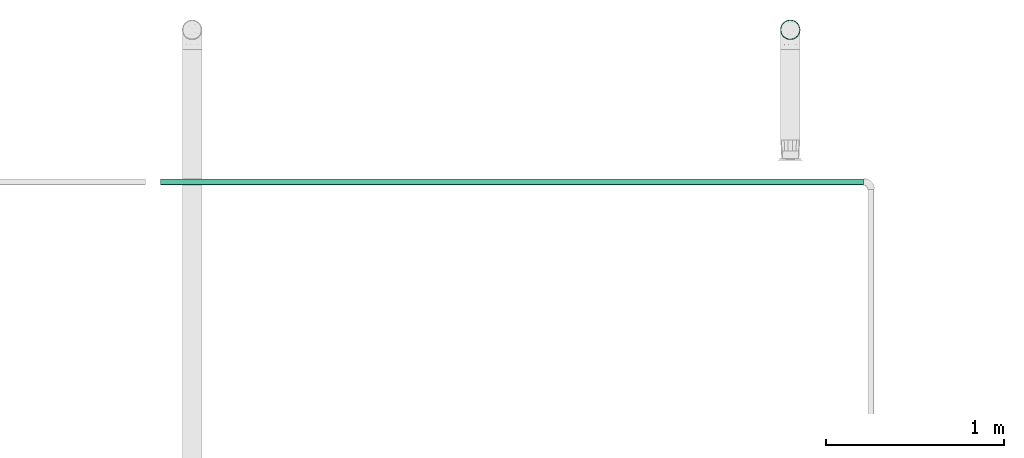
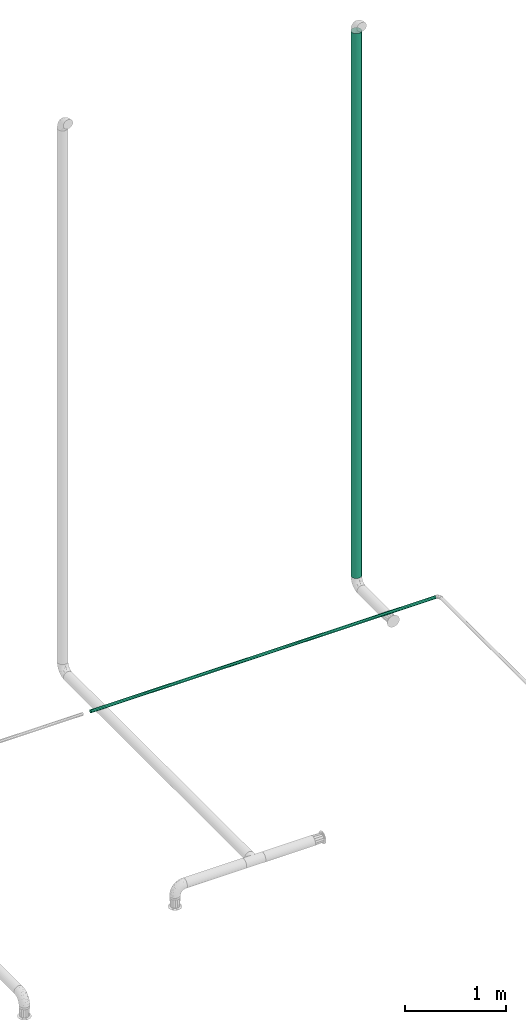
# One storey, part 22 of 123: 2 flow segments.
"""IFC2X3 building model written with IfcOpenShell, lengths in millimetres."""

from ifc_helpers import new_model, entity, si_unit, converted_unit, derived_unit, direction, frame, origin_with_axes, origin_2d_with_axis, place, context, subcontext, project, spatial, hollow_circle, extrude, source, transform, mapped, material, layer, layer_set, layer_usage, type_object, element, save


model = new_model("IFC2X3")

# Units and contexts
model_context = context("Model", 3, precision=1e-05, world=origin_with_axes(), true_north=direction((0.0, 1.0)))
body_context = subcontext(model_context, "Body", "Model", "MODEL_VIEW")
ifc_project = project(units=[si_unit("AREAUNIT", "SQUARE_METRE"), si_unit("VOLUMEUNIT", "CUBIC_METRE", prefix="DECI"), si_unit("TIMEUNIT", "SECOND"), si_unit("THERMODYNAMICTEMPERATUREUNIT", "DEGREE_CELSIUS"), si_unit("PRESSUREUNIT", "PASCAL"), si_unit("MASSUNIT", "GRAM", prefix="KILO"), si_unit("LENGTHUNIT", "METRE", prefix="MILLI"), si_unit("POWERUNIT", "WATT"), si_unit("ELECTRICCURRENTUNIT", "AMPERE"), si_unit("ELECTRICVOLTAGEUNIT", "VOLT"), derived_unit("VOLUMETRICFLOWRATEUNIT", [(si_unit("VOLUMEUNIT", "CUBIC_METRE", prefix="DECI"), 1), (si_unit("TIMEUNIT", "SECOND"), -1)]), derived_unit("LINEARVELOCITYUNIT", [(si_unit("LENGTHUNIT", "METRE"), 1), (si_unit("TIMEUNIT", "SECOND"), -1)]), derived_unit("MASSDENSITYUNIT", [(si_unit("MASSUNIT", "GRAM", prefix="KILO"), 1), (si_unit("VOLUMEUNIT", "CUBIC_METRE"), -1)]), converted_unit("PLANEANGLEUNIT", "DEGREE", entity("IfcRatioMeasure", 0.01745), si_unit("PLANEANGLEUNIT", "RADIAN"), dimensions=[0, 0, 0, 0, 0, 0, 0])], contexts=[model_context])

# Site, building, storey
site_placement = place(None, origin_with_axes())
site = spatial("IfcSite", under=ifc_project, at=site_placement, CompositionType="ELEMENT")
building_placement = place(site_placement, origin_with_axes())
building = spatial("IfcBuilding", under=site, at=building_placement, Name="mc-building", CompositionType="ELEMENT")
storey_placement = place(building_placement, origin_with_axes())
storey = spatial("IfcBuildingStorey", under=building, at=storey_placement, Name="1. Korrus", CompositionType="ELEMENT", Elevation=0.0)

# Flow segments
ifc_material_1 = material(Name="FZ1")
ifc_layer_1 = layer(ifc_material_1, 0.0)
ifc_layer_set_1 = layer_set([ifc_layer_1], Name="FZ1")
ifc_layer_usage_1 = layer_usage(ifc_layer_set_1, "AXIS1", "POSITIVE", 0.0)
duct_segment_type = type_object("IfcDuctSegmentType", PredefinedType="RIGIDSEGMENT")
shared_shape_1 = source(origin_with_axes(), body_context, "Body", "SweptSolid", [
    extrude(hollow_circle(Radius=55.0, WallThickness=2.0, at=origin_2d_with_axis()), frame((0.0, 0.0, 0.0), z_axis=(1.0, 0.0, 0.0), x_axis=(0.0, 1.0, 0.0)), (0.0, 0.0, 1.0), 6595.0),
])
flow_segment_1_placement = place(storey_placement, frame((36391.76813, 13663.57591, 2410.0), z_axis=(0.0, -1.0, 0.0), x_axis=(0.0, 0.0, 1.0)))
element("IfcFlowSegment", 1, at=flow_segment_1_placement, inside=storey, type_object=duct_segment_type, material=ifc_layer_usage_1, context=body_context, shape_type="MappedRepresentation", body=[
    mapped(shared_shape_1, transform((0.0, 0.0, 0.0), scale=1.0)),
])
ifc_material_2 = material(Name="Steel")
ifc_layer_2 = layer(ifc_material_2, 0.0)
ifc_layer_set_2 = layer_set([ifc_layer_2], Name="Steel")
ifc_layer_usage_2 = layer_usage(ifc_layer_set_2, "AXIS1", "POSITIVE", 0.0)
pipe_segment_type = type_object("IfcPipeSegmentType", PredefinedType="RIGIDSEGMENT")
shared_shape_2 = source(origin_with_axes(), body_context, "Body", "SweptSolid", [
    extrude(hollow_circle(Radius=17.5, WallThickness=2.0, at=origin_2d_with_axis()), frame((0.0, 0.0, 0.0), z_axis=(1.0, 0.0, 0.0), x_axis=(0.0, 1.0, 0.0)), (0.0, 0.0, 1.0), 3951.6),
])
flow_segment_2_placement = place(storey_placement, frame((32851.38786, 12807.91734, 2520.89768), z_axis=(0.0, 0.0, 1.0), x_axis=(1.0, 0.0, 0.0)))
element("IfcFlowSegment", 2, at=flow_segment_2_placement, inside=storey, type_object=pipe_segment_type, material=ifc_layer_usage_2, context=body_context, shape_type="MappedRepresentation", body=[
    mapped(shared_shape_2, transform((0.0, 0.0, 0.0), scale=1.0)),
])

save(model, "model.ifc")
